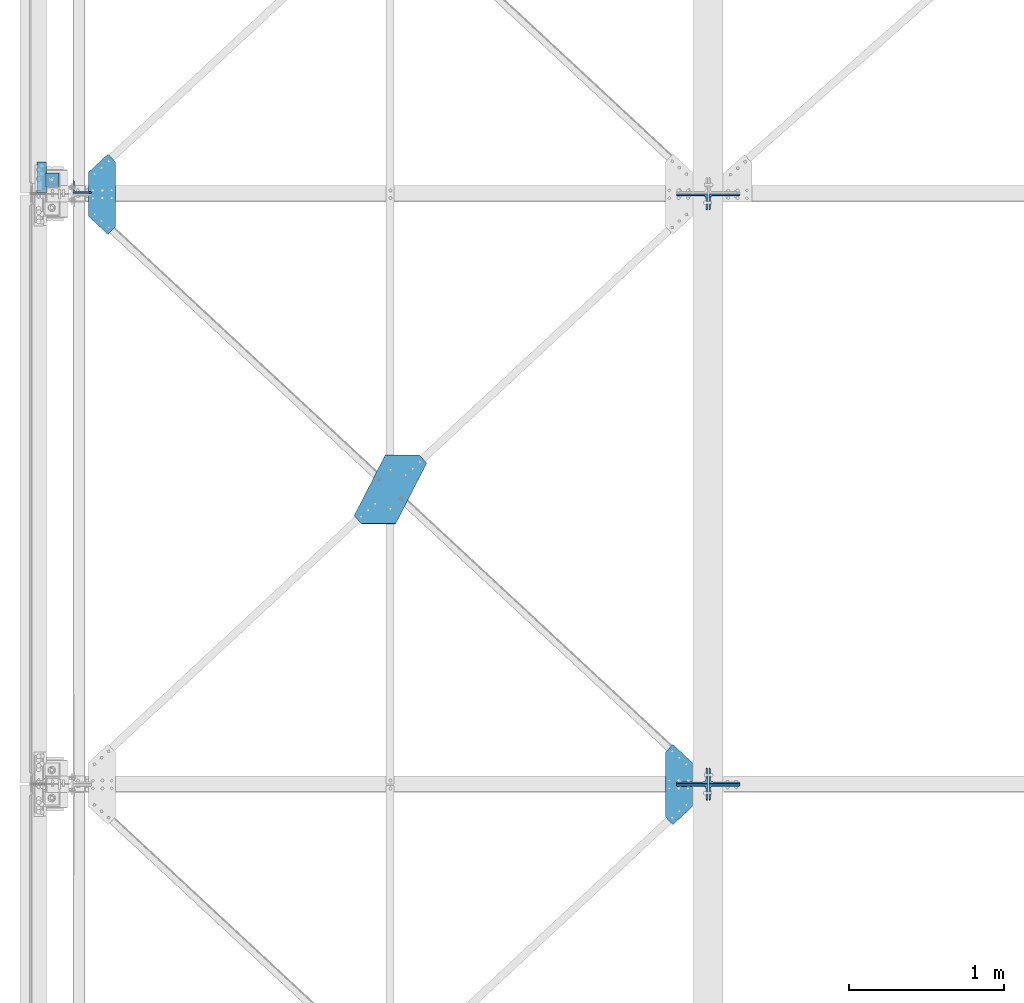
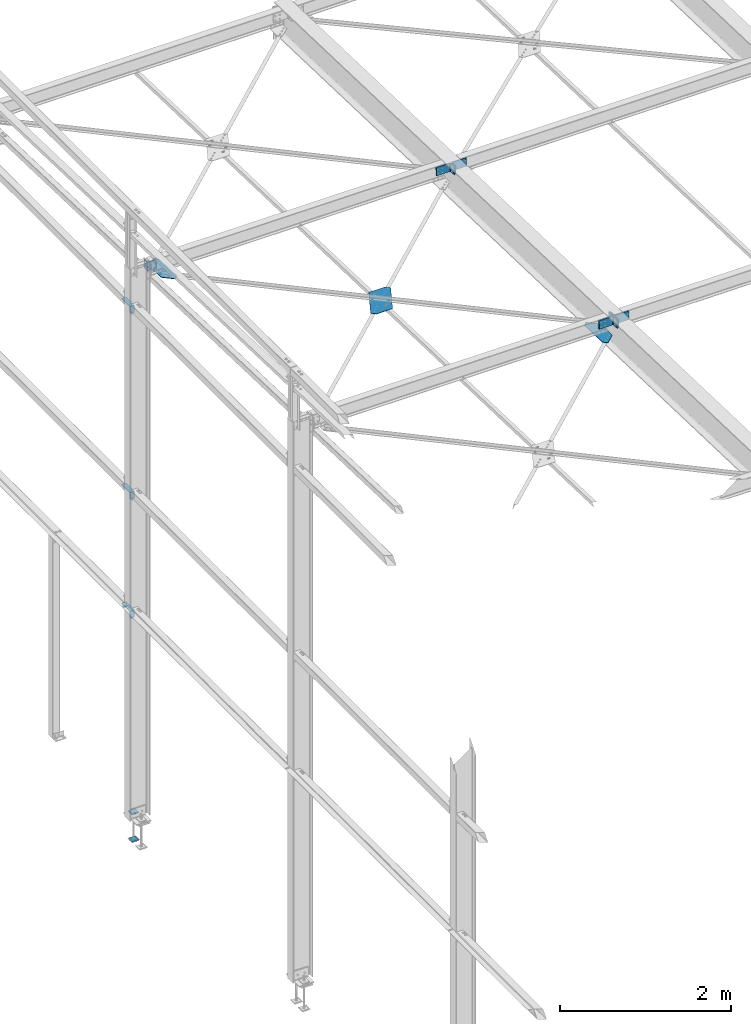
# One storey, part 76 of 496: 8 beams, 7 members, 14 elements without a shape of their own.
"""IFC2X3 building model written with IfcOpenShell, lengths in millimetres."""

from ifc_helpers import new_model, si_unit, frame, origin_with_axes, origin_2d_with_axis, place, context, subcontext, project, spatial, polyline, l_section, outline, extrude, material, type_object, element, aggregate, save


model = new_model("IFC2X3")

# Units and contexts
model_context = context("Model", 3, precision=1e-05, world=origin_with_axes())
body_context = subcontext(model_context, "Body", "Model", "MODEL_VIEW")
ifc_project = project(units=[si_unit("LENGTHUNIT", "METRE", prefix="MILLI"), si_unit("AREAUNIT", "SQUARE_METRE"), si_unit("VOLUMEUNIT", "CUBIC_METRE"), si_unit("MASSUNIT", "GRAM", prefix="KILO"), si_unit("TIMEUNIT", "SECOND"), si_unit("PLANEANGLEUNIT", "RADIAN"), si_unit("SOLIDANGLEUNIT", "STERADIAN"), si_unit("THERMODYNAMICTEMPERATUREUNIT", "DEGREE_CELSIUS"), si_unit("LUMINOUSINTENSITYUNIT", "LUMEN")], contexts=[model_context])

# Site, building, storey
site_placement = place(None, origin_with_axes())
site = spatial("IfcSite", under=ifc_project, at=site_placement, CompositionType="ELEMENT")
building_placement = place(site_placement, origin_with_axes())
building = spatial("IfcBuilding", under=site, at=building_placement, Name="Undefined", CompositionType="ELEMENT")
storey_placement = place(building_placement, origin_with_axes())
storey = spatial("IfcBuildingStorey", under=building, at=storey_placement, Name="Undefined", CompositionType="ELEMENT", Elevation=0.0)

# Assembly, beam
assembly_1_placement = place(storey_placement, origin_with_axes())
assembly_1 = element("IfcElementAssembly", 1, at=assembly_1_placement, inside=storey, AssemblyPlace="NOTDEFINED", PredefinedType="NOTDEFINED")
ifc_material = material(Name="Undefined/S235-E24")
beam_type_1 = type_object("IfcBeamType", PredefinedType="NOTDEFINED")
beam_1_placement = place(assembly_1_placement, frame((2321.30220508621, 9717.61972509604, 7541.51371551223), z_axis=(0.0, 0.031410887010906, 0.999506556345274), x_axis=(-1.0, 0.0, 0.0)))
beam_1 = element("IfcBeam", 2, at=beam_1_placement, type_object=beam_type_1, material=ifc_material, context=body_context, shape_type="SweptSolid", body=[
    extrude(outline(polyline([(0.0, 0.0), (219.999999998594, -9.93168214336038e-10), (420.263031005037, 390.657226561482), (372.604370116365, 441.927673338805), (152.604415892733, 441.927612303649), (-47.6586227425214, 51.2704162588834), (0.0, 0.0)])), frame((0.0, 0.0, -3.0), z_axis=(0.0, 0.0, 1.0), x_axis=(1.0, 0.0, 0.0)), (0.0, 0.0, 1.0), 6.0),
])
aggregate(assembly_1, [beam_1])

assembly_2_placement = place(storey_placement, origin_with_axes())
assembly_2 = element("IfcElementAssembly", 3, at=assembly_2_placement, inside=storey, AssemblyPlace="NOTDEFINED", PredefinedType="NOTDEFINED")
beam_type_2 = type_object("IfcBeamType", PredefinedType="NOTDEFINED")
beam_2_placement = place(assembly_2_placement, frame((190.000000810863, 11537.436072572, 7484.32284643832), z_axis=(0.0, -0.031410887010906, -0.999506556345274), x_axis=(0.732434511694635, 0.680501526716288, -0.0213859349910859)))
beam_2 = element("IfcBeam", 4, at=beam_2_placement, type_object=beam_type_2, material=ifc_material, context=body_context, shape_type="SweptSolid", body=[
    extrude(outline(polyline([(0.0, 0.0), (173.397750853316, 2.20097717829049e-10), (173.397735594586, 70.0000000001428), (-109.18666839611, 373.993011474543), (-179.000320434538, 379.097381591705), (-191.644119262959, 206.167800903238), (0.0, 0.0)])), frame((0.0, 0.0, -3.0), z_axis=(0.0, 0.0, 1.0), x_axis=(1.0, 0.0, 0.0)), (0.0, 0.0, 1.0), 6.0),
])
aggregate(assembly_2, [beam_2])

assembly_3_placement = place(storey_placement, origin_with_axes())
assembly_3 = element("IfcElementAssembly", 5, at=assembly_3_placement, inside=storey, AssemblyPlace="NOTDEFINED", PredefinedType="NOTDEFINED")
beam_3_placement = place(assembly_3_placement, frame((4079.9999991887, 7737.43555853849, 7603.74442003857), z_axis=(0.0, 0.031410887010906, 0.999506556345274), x_axis=(-0.732434513155022, 0.680501525144028, -0.0213859350045245)))
beam_3 = element("IfcBeam", 6, at=beam_3_placement, type_object=beam_type_2, material=ifc_material, context=body_context, shape_type="SweptSolid", body=[
    extrude(outline(polyline([(0.0, 0.0), (173.397750853316, 2.20097717829049e-10), (173.397735594586, 70.0000000001428), (-109.18592071591, 373.992950438941), (-178.999572754413, 379.097320556037), (-191.641067505524, 206.164520263229), (0.0, 0.0)])), frame((0.0, 0.0, -3.0), z_axis=(0.0, 0.0, 1.0), x_axis=(1.0, 0.0, 0.0)), (0.0, 0.0, 1.0), 6.0),
])
aggregate(assembly_3, [beam_3])

# Assembly, member
assembly_4_placement = place(storey_placement, origin_with_axes())
assembly_4 = element("IfcElementAssembly", 7, at=assembly_4_placement, inside=storey, AssemblyPlace="NOTDEFINED", PredefinedType="NOTDEFINED")
member_type_1 = type_object("IfcMemberType", PredefinedType="NOTDEFINED")
member_1_placement = place(assembly_4_placement, frame((4075.00000000072, 11345.141980016, 7533.38204333202), z_axis=(-1.0, 0.0, 0.0), x_axis=(0.0, 0.031410887010906, 0.999506556345274)))
member_1 = element("IfcMember", 8, at=member_1_placement, type_object=member_type_1, material=ifc_material, context=body_context, shape_type="SweptSolid", body=[
    extrude(l_section(Depth=200.0, Width=100.0, Thickness=10.0, FilletRadius=15.0, EdgeRadius=7.5, at=origin_2d_with_axis()), frame((120.0, 0.0, 0.0), z_axis=(-1.0, 0.0, 0.0), x_axis=(0.0, -1.0, 0.0)), (0.0, 0.0, 1.0), 120.0),
])
aggregate(assembly_4, [member_1])

assembly_5_placement = place(storey_placement, origin_with_axes())
assembly_5 = element("IfcElementAssembly", 9, at=assembly_5_placement, inside=storey, AssemblyPlace="NOTDEFINED", PredefinedType="NOTDEFINED")
member_2_placement = place(assembly_5_placement, frame((4285.00000000005, 11348.9113261771, 7653.3228288441), z_axis=(1.0, 0.0, 0.0), x_axis=(0.0, -0.031410887010906, -0.999506556345274)))
member_2 = element("IfcMember", 10, at=member_2_placement, type_object=member_type_1, material=ifc_material, context=body_context, shape_type="SweptSolid", body=[
    extrude(l_section(Depth=200.0, Width=100.0, Thickness=10.0, FilletRadius=15.0, EdgeRadius=7.5, at=origin_2d_with_axis()), frame((120.0, 0.0, 0.0), z_axis=(-1.0, 0.0, 0.0), x_axis=(0.0, -1.0, 0.0)), (0.0, 0.0, 1.0), 120.0),
])
aggregate(assembly_5, [member_2])

assembly_6_placement = place(storey_placement, origin_with_axes())
assembly_6 = element("IfcElementAssembly", 11, at=assembly_6_placement, inside=storey, AssemblyPlace="NOTDEFINED", PredefinedType="NOTDEFINED")
member_3_placement = place(assembly_6_placement, frame((4075.00000000072, 7654.85936797414, 7769.4147863461), z_axis=(-1.0, 0.0, 0.0), x_axis=(0.0, -0.031410887010906, -0.999506556345274)))
member_3 = element("IfcMember", 12, at=member_3_placement, type_object=member_type_1, material=ifc_material, context=body_context, shape_type="SweptSolid", body=[
    extrude(l_section(Depth=200.0, Width=100.0, Thickness=10.0, FilletRadius=15.0, EdgeRadius=7.5, at=origin_2d_with_axis()), frame((120.0, 0.0, 0.0), z_axis=(-1.0, 0.0, 0.0), x_axis=(0.0, -1.0, 0.0)), (0.0, 0.0, 1.0), 120.0),
])
aggregate(assembly_6, [member_3])

assembly_7_placement = place(storey_placement, origin_with_axes())
assembly_7 = element("IfcElementAssembly", 13, at=assembly_7_placement, inside=storey, AssemblyPlace="NOTDEFINED", PredefinedType="NOTDEFINED")
member_4_placement = place(assembly_7_placement, frame((4285.00000000005, 7651.09002180666, 7649.47400083405), z_axis=(1.0, 0.0, 0.0), x_axis=(0.0, 0.031410887010906, 0.999506556345274)))
member_4 = element("IfcMember", 14, at=member_4_placement, type_object=member_type_1, material=ifc_material, context=body_context, shape_type="SweptSolid", body=[
    extrude(l_section(Depth=200.0, Width=100.0, Thickness=10.0, FilletRadius=15.0, EdgeRadius=7.5, at=origin_2d_with_axis()), frame((120.0, 0.0, 0.0), z_axis=(-1.0, 0.0, 0.0), x_axis=(0.0, -1.0, 0.0)), (0.0, 0.0, 1.0), 120.0),
])
aggregate(assembly_7, [member_4])

assembly_8_placement = place(storey_placement, origin_with_axes())
assembly_8 = element("IfcElementAssembly", 15, at=assembly_8_placement, inside=storey, AssemblyPlace="NOTDEFINED", PredefinedType="NOTDEFINED")
member_5_placement = place(assembly_8_placement, frame((4075.00000000072, 7545.14146607884, 7652.80361703019), z_axis=(-1.0, 0.0, 0.0), x_axis=(0.0, 0.031410887010906, 0.999506556345274)))
member_5 = element("IfcMember", 16, at=member_5_placement, type_object=member_type_1, material=ifc_material, context=body_context, shape_type="SweptSolid", body=[
    extrude(l_section(Depth=200.0, Width=100.0, Thickness=10.0, FilletRadius=15.0, EdgeRadius=7.5, at=origin_2d_with_axis()), frame((120.0, 0.0, 0.0), z_axis=(-1.0, 0.0, 0.0), x_axis=(0.0, -1.0, 0.0)), (0.0, 0.0, 1.0), 120.0),
])
aggregate(assembly_8, [member_5])

assembly_9_placement = place(storey_placement, origin_with_axes())
assembly_9 = element("IfcElementAssembly", 17, at=assembly_9_placement, inside=storey, AssemblyPlace="NOTDEFINED", PredefinedType="NOTDEFINED")
member_6_placement = place(assembly_9_placement, frame((4285.00000000005, 7548.9108122399, 7772.74440254227), z_axis=(1.0, 0.0, 0.0), x_axis=(0.0, -0.031410887010906, -0.999506556345274)))
member_6 = element("IfcMember", 18, at=member_6_placement, type_object=member_type_1, material=ifc_material, context=body_context, shape_type="SweptSolid", body=[
    extrude(l_section(Depth=200.0, Width=100.0, Thickness=10.0, FilletRadius=15.0, EdgeRadius=7.5, at=origin_2d_with_axis()), frame((120.0, 0.0, 0.0), z_axis=(-1.0, 0.0, 0.0), x_axis=(0.0, -1.0, 0.0)), (0.0, 0.0, 1.0), 120.0),
])
aggregate(assembly_9, [member_6])

# Assembly, beam
assembly_10_placement = place(storey_placement, origin_with_axes())
assembly_10 = element("IfcElementAssembly", 19, at=assembly_10_placement, inside=storey, AssemblyPlace="NOTDEFINED", PredefinedType="NOTDEFINED")
beam_type_3 = type_object("IfcBeamType", PredefinedType="NOTDEFINED")
beam_4_placement = place(assembly_10_placement, frame((-80.000006857158, 11505.0000006486, 2709.9999839346), z_axis=(0.0, 1.0, 0.0), x_axis=(-1.0, 0.0, 0.0)))
beam_4 = element("IfcBeam", 20, at=beam_4_placement, type_object=beam_type_3, material=ifc_material, context=body_context, shape_type="SweptSolid", body=[
    extrude(l_section(Depth=200.0, Width=100.0, Thickness=10.0, FilletRadius=15.0, EdgeRadius=7.5, at=origin_2d_with_axis()), frame((60.0, 0.0, 0.0), z_axis=(-1.0, 0.0, 0.0), x_axis=(0.0, -1.0, 0.0)), (0.0, 0.0, 1.0), 60.0),
])
aggregate(assembly_10, [beam_4])

assembly_11_placement = place(storey_placement, origin_with_axes())
assembly_11 = element("IfcElementAssembly", 21, at=assembly_11_placement, inside=storey, AssemblyPlace="NOTDEFINED", PredefinedType="NOTDEFINED")
beam_5_placement = place(assembly_11_placement, frame((-80.000006857158, 11505.0000006486, 4399.99998404937), z_axis=(0.0, 1.0, 0.0), x_axis=(-1.0, 0.0, 0.0)))
beam_5 = element("IfcBeam", 22, at=beam_5_placement, type_object=beam_type_3, material=ifc_material, context=body_context, shape_type="SweptSolid", body=[
    extrude(l_section(Depth=200.0, Width=100.0, Thickness=10.0, FilletRadius=15.0, EdgeRadius=7.5, at=origin_2d_with_axis()), frame((60.0, 0.0, 0.0), z_axis=(-1.0, 0.0, 0.0), x_axis=(0.0, -1.0, 0.0)), (0.0, 0.0, 1.0), 60.0),
])
aggregate(assembly_11, [beam_5])

assembly_12_placement = place(storey_placement, origin_with_axes())
assembly_12 = element("IfcElementAssembly", 23, at=assembly_12_placement, inside=storey, AssemblyPlace="NOTDEFINED", PredefinedType="NOTDEFINED")
beam_6_placement = place(assembly_12_placement, frame((-80.000006857158, 11505.0000006486, 7050.0), z_axis=(0.0, 1.0, 0.0), x_axis=(-1.0, 0.0, 0.0)))
beam_6 = element("IfcBeam", 24, at=beam_6_placement, type_object=beam_type_3, material=ifc_material, context=body_context, shape_type="SweptSolid", body=[
    extrude(l_section(Depth=200.0, Width=100.0, Thickness=10.0, FilletRadius=15.0, EdgeRadius=7.5, at=origin_2d_with_axis()), frame((60.0, 0.0, 0.0), z_axis=(-1.0, 0.0, 0.0), x_axis=(0.0, -1.0, 0.0)), (0.0, 0.0, 1.0), 60.0),
])
aggregate(assembly_12, [beam_6])

# Assembly, member
assembly_13_placement = place(storey_placement, origin_with_axes())
assembly_13 = element("IfcElementAssembly", 25, at=assembly_13_placement, inside=storey, AssemblyPlace="NOTDEFINED", PredefinedType="NOTDEFINED")
member_type_2 = type_object("IfcMemberType", PredefinedType="NOTDEFINED")
member_7_placement = place(assembly_13_placement, frame((149.999999999402, 11441.0954703031, 7530.36653931623), z_axis=(1.0, 0.0, 0.0), x_axis=(0.0, 0.031410887010906, 0.999506556345274)))
member_7 = element("IfcMember", 26, at=member_7_placement, type_object=member_type_2, material=ifc_material, context=body_context, shape_type="SweptSolid", body=[
    extrude(l_section(Depth=120.0, Width=80.0, Thickness=10.0, FilletRadius=11.0, EdgeRadius=5.5, at=origin_2d_with_axis()), frame((120.0, 0.0, 0.0), z_axis=(-1.0, 0.0, 0.0), x_axis=(0.0, -1.0, 0.0)), (0.0, 0.0, 1.0), 120.0),
])
aggregate(assembly_13, [member_7])

# Assembly, beams
assembly_14_placement = place(storey_placement, origin_with_axes())
assembly_14 = element("IfcElementAssembly", 27, at=assembly_14_placement, inside=storey, Name="PS24", AssemblyPlace="NOTDEFINED", PredefinedType="NOTDEFINED")
beam_type_4 = type_object("IfcBeamType", PredefinedType="NOTDEFINED")
beam_7_placement = place(assembly_14_placement, frame((0.0, 11534.9971504447, -177.5), z_axis=(0.0, 0.0, 1.0), x_axis=(-1.0, 0.0, 0.0)))
beam_7 = element("IfcBeam", 28, at=beam_7_placement, type_object=beam_type_4, material=ifc_material, context=body_context, shape_type="SweptSolid", body=[
    extrude(outline(polyline([(0.0, 0.0), (90.0, 0.0), (90.0, 90.0), (0.0, 90.0), (0.0, 0.0)])), frame((0.0, 0.0, -7.5), z_axis=(0.0, 0.0, 1.0), x_axis=(1.0, 0.0, 0.0)), (0.0, 0.0, 1.0), 15.0),
])
beam_8_placement = place(assembly_14_placement, frame((0.0, 11534.9971504447, -572.5), z_axis=(0.0, 0.0, 1.0), x_axis=(-1.0, 0.0, 0.0)))
beam_8 = element("IfcBeam", 29, at=beam_8_placement, type_object=beam_type_4, material=ifc_material, context=body_context, shape_type="SweptSolid", body=[
    extrude(outline(polyline([(0.0, 0.0), (90.0, 0.0), (90.0, 90.0), (0.0, 90.0), (0.0, 0.0)])), frame((0.0, 0.0, -7.5), z_axis=(0.0, 0.0, 1.0), x_axis=(1.0, 0.0, 0.0)), (0.0, 0.0, 1.0), 15.0),
])
aggregate(assembly_14, [beam_7, beam_8])

save(model, "model.ifc")
